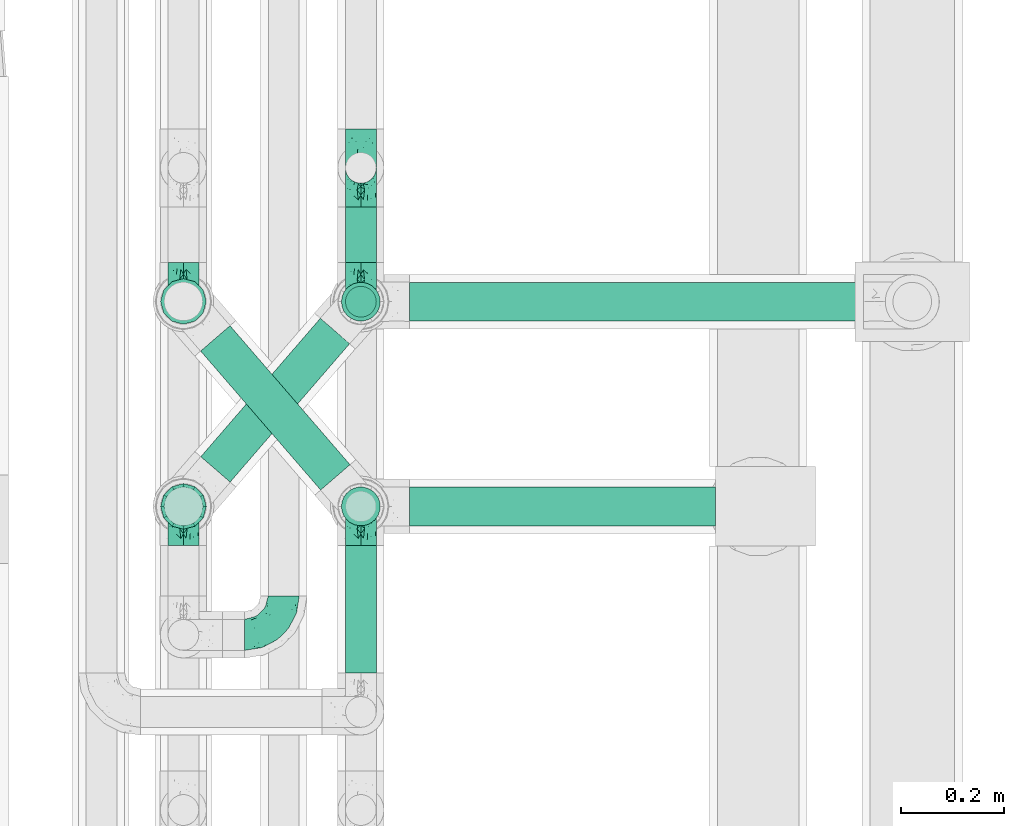
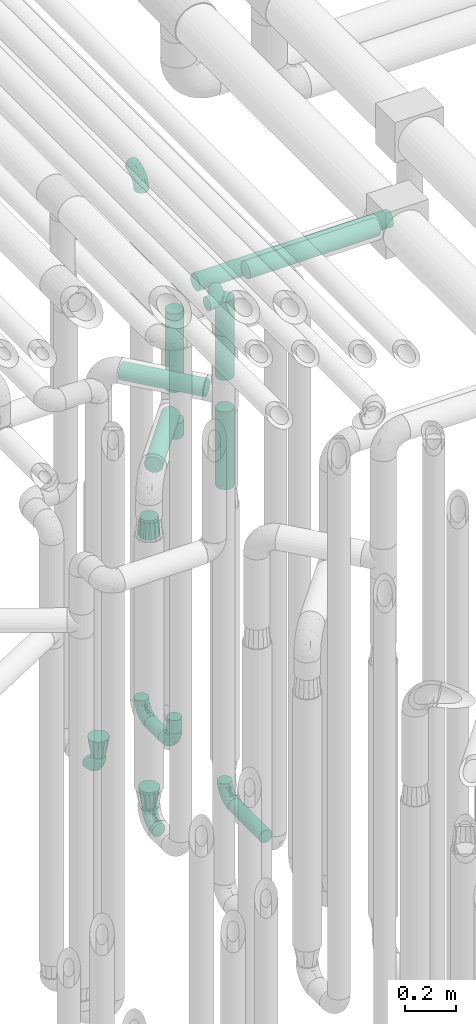
# One storey, part 625 of 827: 11 flow segments, 10 flow fittings.
"""IFC2X3 building model written with IfcOpenShell, lengths in millimetres."""

from ifc_helpers import new_model, entity, si_unit, converted_unit, derived_unit, direction, frame, origin, origin_2d_with_axis, place, context, subcontext, project, spatial, circle, extrude, faceted_brep, source, transform, mapped, material, type_object, type_shapes, element, save


model = new_model("IFC2X3")

# Units and contexts
model_context = context("Model", 3, precision=0.01, world=origin(), true_north=direction((6.12303176911189e-17, 1.0)))
body_context = subcontext(model_context, "Body", "Model", "MODEL_VIEW")
ifc_project = project(units=[si_unit("LENGTHUNIT", "METRE", prefix="MILLI"), si_unit("AREAUNIT", "SQUARE_METRE"), si_unit("VOLUMEUNIT", "CUBIC_METRE"), converted_unit("PLANEANGLEUNIT", "DEGREE", entity("IfcRatioMeasure", 0.0174532925199433), si_unit("PLANEANGLEUNIT", "RADIAN"), dimensions=[0, 0, 0, 0, 0, 0, 0]), si_unit("MASSUNIT", "GRAM", prefix="KILO"), derived_unit("MASSDENSITYUNIT", [(si_unit("MASSUNIT", "GRAM", prefix="KILO"), 1), (si_unit("LENGTHUNIT", "METRE"), -3)]), derived_unit("MOMENTOFINERTIAUNIT", [(si_unit("LENGTHUNIT", "METRE"), 4)]), si_unit("TIMEUNIT", "SECOND"), si_unit("FREQUENCYUNIT", "HERTZ"), si_unit("THERMODYNAMICTEMPERATUREUNIT", "DEGREE_CELSIUS"), derived_unit("THERMALTRANSMITTANCEUNIT", [(si_unit("MASSUNIT", "GRAM", prefix="KILO"), 1), (si_unit("THERMODYNAMICTEMPERATUREUNIT", "KELVIN"), -1), (si_unit("TIMEUNIT", "SECOND"), -3)]), derived_unit("VOLUMETRICFLOWRATEUNIT", [(si_unit("LENGTHUNIT", "METRE"), 3), (si_unit("TIMEUNIT", "SECOND"), -1)]), derived_unit("MASSFLOWRATEUNIT", [(si_unit("MASSUNIT", "GRAM", prefix="KILO"), 1), (si_unit("TIMEUNIT", "SECOND"), -1)]), derived_unit("ROTATIONALFREQUENCYUNIT", [(si_unit("TIMEUNIT", "SECOND"), -1)]), si_unit("ELECTRICCURRENTUNIT", "AMPERE"), si_unit("ELECTRICVOLTAGEUNIT", "VOLT"), si_unit("POWERUNIT", "WATT"), si_unit("FORCEUNIT", "NEWTON", prefix="KILO"), si_unit("ILLUMINANCEUNIT", "LUX"), si_unit("LUMINOUSFLUXUNIT", "LUMEN"), si_unit("LUMINOUSINTENSITYUNIT", "CANDELA"), derived_unit("USERDEFINED", [(si_unit("MASSUNIT", "GRAM", prefix="KILO"), -1), (si_unit("LENGTHUNIT", "METRE"), -2), (si_unit("TIMEUNIT", "SECOND"), 3), (si_unit("LUMINOUSFLUXUNIT", "LUMEN"), 1)]), derived_unit("LINEARVELOCITYUNIT", [(si_unit("LENGTHUNIT", "METRE"), 1), (si_unit("TIMEUNIT", "SECOND"), -1)]), si_unit("PRESSUREUNIT", "PASCAL"), derived_unit("USERDEFINED", [(si_unit("LENGTHUNIT", "METRE"), -2), (si_unit("MASSUNIT", "GRAM", prefix="KILO"), 1), (si_unit("TIMEUNIT", "SECOND"), -2)]), derived_unit("LINEARFORCEUNIT", [(si_unit("MASSUNIT", "GRAM", prefix="KILO"), 1), (si_unit("LENGTHUNIT", "METRE"), 1), (si_unit("TIMEUNIT", "SECOND"), -2), (si_unit("LENGTHUNIT", "METRE"), -1)]), derived_unit("PLANARFORCEUNIT", [(si_unit("MASSUNIT", "GRAM", prefix="KILO"), 1), (si_unit("LENGTHUNIT", "METRE"), 1), (si_unit("TIMEUNIT", "SECOND"), -2), (si_unit("LENGTHUNIT", "METRE"), -2)])], contexts=[model_context])

# Site, building, storey
site_placement = place(None, origin())
site = spatial("IfcSite", under=ifc_project, at=site_placement, CompositionType="ELEMENT")
building_placement = place(site_placement, origin())
building = spatial("IfcBuilding", under=site, at=building_placement, CompositionType="ELEMENT")
storey_placement = place(building_placement, frame((0.0, 0.0, 28200.0)))
storey = spatial("IfcBuildingStorey", under=building, at=storey_placement, Name="08", CompositionType="ELEMENT", Elevation=28200.0)

# Flow segments
pipe_segment_type = type_object("IfcPipeSegmentType", PredefinedType="NOTDEFINED")
flow_segment_1_placement = place(storey_placement, frame((36943.44, 12257.17, 368.4)))
element("IfcFlowSegment", 1, at=flow_segment_1_placement, inside=storey, type_object=pipe_segment_type, context=body_context, shape_type="SweptSolid", body=[
    extrude(circle(Radius=30.0, at=origin_2d_with_axis()), frame((31.6, 0.0, 31.6), z_axis=(0.0, 1.0, 0.0), x_axis=(1.0, 0.0, 0.0)), (0.0, 0.0, 1.0), 247.999981999989),
])
flow_segment_2_placement = place(storey_placement, frame((36943.44, 13055.64, 368.4)))
element("IfcFlowSegment", 2, at=flow_segment_2_placement, inside=storey, type_object=pipe_segment_type, context=body_context, shape_type="SweptSolid", body=[
    extrude(circle(Radius=30.0, at=origin_2d_with_axis()), frame((31.6, 0.0, 31.6), z_axis=(0.0, 1.0, 0.0), x_axis=(-1.0, 0.0, 0.0)), (0.0, 0.0, 1.0), 108.562571608464),
])
flow_segment_3_placement = place(storey_placement, frame((36943.44, 12948.05, 476.0)))
element("IfcFlowSegment", 3, at=flow_segment_3_placement, inside=storey, type_object=pipe_segment_type, context=body_context, shape_type="SweptSolid", body=[
    extrude(circle(Radius=30.0, at=origin_2d_with_axis()), frame((31.6, 31.6, 0.0)), (0.0, 0.0, 1.0), 64.0000000000244),
])
flow_segment_4_placement = place(storey_placement, frame((36935.69, 12940.3, 2126.0)))
element("IfcFlowSegment", 4, at=flow_segment_4_placement, inside=storey, type_object=pipe_segment_type, context=body_context, shape_type="SweptSolid", body=[
    extrude(circle(Radius=37.75, at=origin_2d_with_axis()), frame((39.35, 39.35, 0.0), z_axis=(0.0, 0.0, 1.0), x_axis=(-1.0, 0.0, 0.0)), (0.0, 0.0, 1.0), 378.999999999992),
])
flow_segment_5_placement = place(storey_placement, frame((37070.03, 12940.3, 2560.65)))
element("IfcFlowSegment", 5, at=flow_segment_5_placement, inside=storey, type_object=pipe_segment_type, context=body_context, shape_type="SweptSolid", body=[
    extrude(circle(Radius=37.75, at=origin_2d_with_axis()), frame((0.0, 39.35, 39.35), z_axis=(1.0, 0.0, 0.0), x_axis=(0.0, -1.0, 0.0)), (0.0, 0.0, 1.0), 883.265688415884),
])
flow_segment_6_placement = place(storey_placement, frame((36935.69, 12541.83, 2426.0)))
element("IfcFlowSegment", 6, at=flow_segment_6_placement, inside=storey, type_object=pipe_segment_type, context=body_context, shape_type="SweptSolid", body=[
    extrude(circle(Radius=37.75, at=origin_2d_with_axis()), frame((39.35, 39.35, 0.0), z_axis=(-2.14503310068031e-08, 1.89574983412965e-07, 1.0), x_axis=(-1.0, 0.0, -2.14503310068034e-08)), (0.0, 0.0, 1.0), 378.904960794338),
])
flow_segment_7_placement = place(storey_placement, frame((37070.03, 12541.83, 2860.56)))
element("IfcFlowSegment", 7, at=flow_segment_7_placement, inside=storey, type_object=pipe_segment_type, context=body_context, shape_type="SweptSolid", body=[
    extrude(circle(Radius=37.75, at=origin_2d_with_axis()), frame((0.0, 39.35, 39.35), z_axis=(1.0, 0.0, 0.0), x_axis=(0.0, 1.0, 0.0)), (0.0, 0.0, 1.0), 595.765098762424),
])
flow_segment_8_placement = place(storey_placement, frame((36661.57, 12611.47, 2310.65)))
element("IfcFlowSegment", 8, at=flow_segment_8_placement, inside=storey, type_object=pipe_segment_type, context=body_context, shape_type="SweptSolid", body=[
    extrude(circle(Radius=37.75, at=origin_2d_with_axis()), frame((30.17, 296.83, 39.35), z_axis=(0.65359148401651, -0.756847522306242, 0.0), x_axis=(-0.756847522306242, -0.65359148401651, 0.0)), (0.0, 0.0, 1.0), 357.482862990724),
])
flow_segment_9_placement = place(storey_placement, frame((36935.69, 12541.83, 1900.0)))
element("IfcFlowSegment", 9, at=flow_segment_9_placement, inside=storey, type_object=pipe_segment_type, context=body_context, shape_type="SweptSolid", body=[
    extrude(circle(Radius=37.75, at=origin_2d_with_axis()), frame((39.35, 39.35, 0.0), z_axis=(0.0, 0.0, 1.0), x_axis=(-1.0, 0.0, 0.0)), (0.0, 0.0, 1.0), 374.000000000002),
])
flow_segment_10_placement = place(storey_placement, frame((36661.85, 12626.98, 2010.65)))
element("IfcFlowSegment", 10, at=flow_segment_10_placement, inside=storey, type_object=pipe_segment_type, context=body_context, shape_type="SweptSolid", body=[
    extrude(circle(Radius=37.75, at=origin_2d_with_axis()), frame((30.17, 26.27, 39.35), z_axis=(0.653617255256322, 0.756825266247891, 0.0), x_axis=(0.756825266247891, -0.653617255256322, 0.0)), (0.0, 0.0, 1.0), 356.010747294406),
])
flow_segment_11_placement = place(storey_placement, frame((36935.69, 12940.3, 1900.0)))
element("IfcFlowSegment", 11, at=flow_segment_11_placement, inside=storey, type_object=pipe_segment_type, context=body_context, shape_type="SweptSolid", body=[
    extrude(circle(Radius=37.75, at=origin_2d_with_axis()), frame((39.35, 39.35, 0.0), z_axis=(0.0, 0.0, 1.0), x_axis=(-1.0, 0.0, 0.0)), (0.0, 0.0, 1.0), 74.0000000000005),
])

# Flow fittings
ifc_material = material()
pipe_fitting_type_1 = type_object("IfcPipeFittingType", Name="ADSK_1", PredefinedType="NOTDEFINED", material=ifc_material)
shared_shape_1 = source(origin(), body_context, "Body", "Brep", [
    faceted_brep([(-76.0, 15.07, -26.11), (-76.0, 7.8, -29.12), (-76.0, 0.0, -30.15), (-76.0, -7.8, -29.12), (-76.0, -15.08, -26.11), (-76.0, -21.32, -21.32), (-76.0, -26.11, -15.08), (-76.0, -29.12, -7.8), (-76.0, -30.15, 0.0), (-76.0, -29.12, 7.8), (-76.0, -26.11, 15.07), (-76.0, -21.32, 21.32), (-76.0, -15.08, 26.11), (-76.0, -7.8, 29.12), (-76.0, 0.0, 30.15), (-76.0, 7.8, 29.12), (-76.0, 15.07, 26.11), (-76.0, 21.32, 21.32), (-76.0, 26.11, 15.07), (-76.0, 29.12, 7.8), (-76.0, 30.15, 0.0), (-76.0, 29.12, -7.8), (-76.0, 26.11, -15.08), (-76.0, 21.32, -21.32), (0.0, 76.0, -30.15), (-7.8, 76.0, -29.12), (-15.07, 76.0, -26.11), (-21.32, 76.0, -21.32), (-26.11, 76.0, -15.08), (-29.12, 76.0, -7.8), (-30.15, 76.0, 0.0), (-29.12, 76.0, 7.8), (-26.11, 76.0, 15.07), (-21.32, 76.0, 21.32), (-15.07, 76.0, 26.11), (-7.8, 76.0, 29.12), (0.0, 76.0, 30.15), (7.8, 76.0, 29.12), (15.08, 76.0, 26.11), (21.32, 76.0, 21.32), (26.11, 76.0, 15.07), (29.12, 76.0, 7.8), (30.15, 76.0, 0.0), (29.12, 76.0, -7.8), (26.11, 76.0, -15.08), (21.32, 76.0, -21.32), (15.08, 76.0, -26.11), (7.8, 76.0, -29.12), (10.79, 31.43, 21.07), (4.32, 31.7, 25.72), (1.65, 15.19, 19.92), (-61.17, -27.8, 0.0), (-51.1, -25.49, 9.84), (-56.14, -10.61, 27.27), (-31.7, -4.32, 25.72), (-39.75, 1.72, 29.41), (-43.2, -24.95, 0.0), (-1.86, 1.86, 0.0), (4.49, 7.65, 5.78), (-7.82, -4.61, 5.83), (-56.21, -22.79, 17.21), (-58.98, -3.38, 29.7), (-53.96, 5.6, 30.07), (-10.86, 10.86, 25.48), (-17.2, -2.6, 20.44), (-49.15, -16.01, 22.7), (-22.18, -14.24, 7.99), (-28.4, -17.42, 0.0), (-13.61, -9.88, 0.0), (-39.0, 23.48, 27.76), (-58.76, 12.54, 28.36), (-41.61, 15.41, 29.48), (16.01, 49.15, 22.7), (-58.55, 25.93, 19.53), (-51.53, 33.5, 13.51), (-64.92, 28.76, 12.4), (-7.48, 23.14, 28.25), (-1.72, 39.75, 29.41), (-12.04, 27.88, 29.88), (-63.91, 18.81, 24.52), (-11.63, 65.16, 28.18), (-4.97, 57.02, 30.05), (9.88, 13.61, 0.0), (-62.5, 31.74, 5.02), (-45.17, 30.98, 21.2), (-21.78, 9.76, 28.58), (10.61, 56.14, 27.27), (-32.09, 54.42, 13.26), (22.79, 56.21, 17.21), (15.38, 31.17, 15.63), (25.49, 51.1, 9.84), (21.84, 36.35, 5.92), (24.95, 43.2, 0.0), (3.38, 58.98, 29.7), (-31.17, -15.38, 15.63), (-39.39, 41.78, 15.45), (-34.56, 41.13, 20.79), (-39.81, -23.25, 5.49), (27.8, 61.17, 0.0), (-31.74, 62.5, 5.02), (-53.07, 36.29, 0.0), (-42.95, 42.95, 7.29), (-36.29, 53.07, 0.0), (-19.83, 58.51, 24.79), (-25.48, 60.2, 19.41), (-14.53, 50.96, 28.57), (-13.31, 37.09, 30.07), (-26.16, 40.06, 26.4), (-32.43, -10.35, 21.9), (17.42, 28.4, 0.0), (14.24, 22.18, 7.99), (-38.67, 9.72, 30.15), (-24.66, 17.36, 30.09), (-37.08, 31.49, 24.99), (-49.27, 22.83, 25.24), (-20.8, 38.81, 28.63), (-27.58, 27.58, 29.2), (-36.07, -20.23, 10.71), (-15.19, -6.16, 14.9), (6.6, 15.4, 14.49), (-2.51, 2.51, 11.35), (-65.16, 11.63, -28.18), (-49.15, -16.01, -22.7), (-57.02, 4.97, -30.05), (-25.93, 58.55, -19.53), (-33.5, 51.53, -13.51), (-28.76, 64.92, -12.4), (-60.2, 25.48, -19.41), (-58.51, 19.83, -24.79), (4.61, 7.82, -5.83), (-7.65, -4.49, -5.78), (-2.51, 2.51, -11.35), (-62.5, 31.74, -5.02), (-50.96, 14.53, -28.57), (-37.09, 13.31, -30.07), (-42.95, 42.95, -7.29), (25.49, 51.1, -9.84), (22.79, 56.21, -17.21), (-40.06, 26.16, -26.4), (3.38, 58.98, -29.7), (-5.6, 53.96, -30.07), (-27.88, 12.04, -29.88), (-9.76, 21.78, -28.58), (-23.14, 7.48, -28.25), (-51.1, -25.49, -9.84), (15.38, 31.17, -15.63), (16.01, 49.15, -22.7), (-23.48, 39.0, -27.76), (-12.54, 58.76, -28.36), (-15.41, 41.61, -29.48), (-56.21, -22.79, -17.21), (-9.72, 38.67, -30.15), (-17.36, 24.66, -30.09), (-22.18, -14.24, -7.99), (-41.13, 34.56, -20.79), (-31.74, 62.5, -5.02), (-58.98, -3.38, -29.7), (-31.17, -15.38, -15.63), (-56.14, -10.61, -27.27), (14.24, 22.18, -7.99), (23.25, 39.81, -5.49), (-31.49, 37.08, -24.99), (-15.19, -6.16, -14.9), (1.65, 15.19, -19.92), (-18.81, 63.91, -24.52), (-32.59, -11.62, -20.84), (-31.7, -4.32, -25.72), (-17.2, -2.6, -20.44), (-39.75, 1.72, -29.41), (-54.42, 32.09, -13.26), (-30.98, 45.17, -21.2), (10.61, 56.14, -27.27), (10.23, 31.31, -21.52), (4.32, 31.7, -25.72), (-41.78, 39.39, -15.45), (-1.72, 39.75, -29.41), (-36.35, -21.84, -5.92), (-22.83, 49.27, -25.24), (-38.81, 20.8, -28.63), (-27.58, 27.58, -29.2), (-10.86, 10.86, -25.48), (20.23, 36.07, -10.71), (6.6, 15.4, -14.49)], [[[0, 1, 2, 3, 4, 5, 6, 7, 8, 9, 10, 11, 12, 13, 14, 15, 16, 17, 18, 19, 20, 21, 22, 23]], [[24, 25, 26, 27, 28, 29, 30, 31, 32, 33, 34, 35, 36, 37, 38, 39, 40, 41, 42, 43, 44, 45, 46, 47]], [[48, 49, 50]], [[51, 52, 9]], [[53, 54, 55]], [[9, 52, 10]], [[56, 52, 51]], [[57, 58, 59]], [[11, 10, 60]], [[14, 61, 62]], [[63, 54, 64]], [[65, 12, 11]], [[65, 53, 12]], [[66, 67, 68]], [[69, 70, 71]], [[72, 39, 38]], [[73, 74, 75]], [[15, 70, 16]], [[76, 77, 78]], [[16, 79, 17]], [[13, 61, 14]], [[35, 80, 81]], [[14, 62, 15]], [[17, 73, 18]], [[57, 82, 58]], [[20, 19, 83]], [[75, 19, 18]], [[70, 15, 62]], [[73, 84, 74]], [[78, 85, 76]], [[38, 86, 72]], [[32, 31, 87]], [[88, 89, 90]], [[91, 92, 90]], [[72, 86, 49]], [[36, 93, 37]], [[75, 83, 19]], [[36, 35, 81]], [[60, 94, 65]], [[40, 90, 41]], [[95, 96, 87]], [[88, 90, 40]], [[66, 97, 67]], [[90, 98, 41]], [[40, 39, 88]], [[99, 31, 30]], [[20, 83, 100]], [[101, 102, 100]], [[52, 60, 10]], [[102, 99, 30]], [[96, 103, 104]], [[83, 101, 100]], [[12, 53, 13]], [[104, 103, 33]], [[105, 106, 81]], [[107, 105, 103]], [[64, 54, 108]], [[80, 103, 105]], [[80, 35, 34]], [[34, 33, 103]], [[86, 38, 37]], [[109, 110, 82]], [[71, 111, 112]], [[69, 107, 113]], [[79, 73, 17]], [[114, 113, 84]], [[33, 32, 104]], [[115, 107, 116]], [[105, 115, 106]], [[93, 81, 77]], [[54, 53, 65]], [[61, 53, 55]], [[108, 94, 64]], [[54, 63, 85]], [[93, 86, 37]], [[77, 76, 49]], [[77, 49, 86]], [[49, 63, 50]], [[60, 52, 117]], [[65, 11, 60]], [[39, 72, 88]], [[89, 88, 72]], [[71, 70, 62]], [[79, 70, 114]], [[103, 96, 107]], [[69, 113, 114]], [[112, 106, 116]], [[77, 81, 106]], [[112, 116, 71]], [[112, 55, 85]], [[64, 50, 63]], [[57, 59, 68]], [[32, 87, 104]], [[96, 104, 87]], [[94, 118, 64]], [[50, 119, 89]], [[50, 64, 118]], [[50, 89, 48]], [[81, 93, 36]], [[86, 93, 77]], [[53, 61, 13]], [[62, 61, 55]], [[71, 62, 111]], [[69, 71, 116]], [[95, 101, 74]], [[99, 101, 87]], [[118, 66, 59]], [[117, 97, 66]], [[117, 66, 94]], [[91, 89, 110]], [[91, 110, 109]], [[110, 89, 119]], [[9, 8, 51]], [[98, 90, 92]], [[98, 42, 41]], [[101, 83, 74]], [[101, 99, 102]], [[87, 31, 99]], [[62, 55, 111]], [[55, 112, 111]], [[107, 69, 116]], [[70, 69, 114]], [[107, 96, 113]], [[84, 113, 96]], [[84, 96, 95]], [[114, 84, 73]], [[70, 79, 16]], [[73, 79, 114]], [[54, 85, 55]], [[76, 85, 63]], [[49, 76, 63]], [[77, 106, 78]], [[106, 112, 78]], [[85, 78, 112]], [[73, 75, 18]], [[83, 75, 74]], [[103, 80, 34]], [[81, 80, 105]], [[101, 95, 87]], [[84, 95, 74]], [[106, 115, 116]], [[105, 107, 115]], [[120, 59, 58]], [[82, 110, 58]], [[119, 58, 110]], [[118, 59, 120]], [[66, 68, 59]], [[54, 65, 108]], [[94, 108, 65]], [[66, 118, 94]], [[50, 118, 120]], [[50, 120, 119]], [[119, 120, 58]], [[89, 72, 48]], [[49, 48, 72]], [[60, 117, 94]], [[117, 52, 97]], [[52, 56, 97]], [[67, 97, 56]], [[92, 91, 109]], [[89, 91, 90]], [[121, 1, 0]], [[122, 5, 4]], [[2, 1, 123]], [[124, 125, 126]], [[127, 128, 23]], [[129, 130, 131]], [[100, 132, 20]], [[133, 134, 123]], [[135, 100, 102]], [[136, 137, 44]], [[133, 128, 138]], [[24, 139, 140]], [[141, 142, 143]], [[121, 128, 133]], [[6, 144, 7]], [[137, 145, 146]], [[144, 51, 7]], [[147, 148, 149]], [[144, 6, 150]], [[149, 151, 152]], [[153, 68, 67]], [[154, 128, 127]], [[30, 155, 102]], [[43, 42, 98]], [[156, 3, 2]], [[157, 144, 150]], [[158, 4, 3]], [[24, 140, 25]], [[155, 135, 102]], [[159, 160, 109]], [[30, 29, 155]], [[147, 138, 161]], [[27, 124, 28]], [[57, 129, 82]], [[162, 163, 131]], [[27, 26, 164]], [[148, 26, 25]], [[165, 166, 167]], [[24, 47, 139]], [[143, 168, 141]], [[22, 21, 169]], [[125, 124, 170]], [[148, 25, 140]], [[46, 146, 171]], [[158, 122, 4]], [[0, 23, 128]], [[1, 121, 123]], [[109, 82, 159]], [[45, 44, 137]], [[146, 46, 45]], [[136, 43, 98]], [[132, 21, 20]], [[136, 98, 92]], [[172, 173, 146]], [[46, 171, 47]], [[43, 136, 44]], [[174, 154, 169]], [[171, 173, 175]], [[6, 5, 150]], [[126, 29, 28]], [[176, 56, 144]], [[122, 158, 166]], [[164, 124, 27]], [[177, 161, 170]], [[23, 22, 127]], [[178, 138, 179]], [[133, 178, 134]], [[156, 123, 168]], [[156, 158, 3]], [[168, 143, 166]], [[168, 166, 158]], [[166, 180, 167]], [[173, 171, 146]], [[139, 171, 175]], [[172, 145, 163]], [[173, 180, 142]], [[5, 122, 150]], [[157, 150, 122]], [[137, 136, 181]], [[146, 45, 137]], [[149, 148, 140]], [[164, 148, 177]], [[128, 154, 138]], [[147, 161, 177]], [[152, 134, 179]], [[168, 123, 134]], [[152, 179, 149]], [[152, 175, 142]], [[57, 130, 129]], [[157, 165, 167]], [[22, 169, 127]], [[154, 127, 169]], [[163, 167, 180]], [[162, 157, 167]], [[173, 163, 180]], [[182, 163, 145]], [[123, 156, 2]], [[158, 156, 168]], [[171, 139, 47]], [[140, 139, 175]], [[149, 140, 151]], [[147, 149, 179]], [[174, 135, 125]], [[132, 135, 169]], [[176, 157, 153]], [[176, 153, 67]], [[153, 157, 162]], [[182, 159, 129]], [[181, 160, 159]], [[181, 159, 145]], [[51, 144, 56]], [[51, 8, 7]], [[135, 132, 100]], [[169, 21, 132]], [[126, 155, 29]], [[135, 155, 125]], [[140, 175, 151]], [[175, 152, 151]], [[138, 147, 179]], [[148, 147, 177]], [[138, 154, 161]], [[170, 161, 154]], [[170, 154, 174]], [[177, 170, 124]], [[148, 164, 26]], [[124, 164, 177]], [[173, 142, 175]], [[143, 142, 180]], [[166, 143, 180]], [[168, 134, 141]], [[134, 152, 141]], [[142, 141, 152]], [[124, 126, 28]], [[155, 126, 125]], [[128, 121, 0]], [[123, 121, 133]], [[135, 174, 169]], [[170, 174, 125]], [[134, 178, 179]], [[133, 138, 178]], [[130, 153, 162]], [[68, 153, 130]], [[57, 68, 130]], [[182, 129, 131]], [[159, 82, 129]], [[157, 122, 165]], [[166, 165, 122]], [[163, 162, 167]], [[162, 131, 130]], [[145, 172, 146]], [[163, 173, 172]], [[159, 182, 145]], [[131, 163, 182]], [[56, 176, 67]], [[157, 176, 144]], [[137, 181, 145]], [[181, 136, 160]], [[136, 92, 160]], [[109, 160, 92]]]),
])
type_shapes(pipe_fitting_type_1, [shared_shape_1])
for number, where, z_axis, x_axis, name in (
    (12, (36975.03, 12581.17, 400.0), (1.0, 0.0, 0.0), (0.0, 1.0, 0.0), "ADSK_1"),
    (13, (36975.03, 13240.2, 400.0), (-1.0, 0.0, 0.0), (0.0, 0.0, -1.0), "ADSK_1"),
    (14, (36975.03, 12979.64, 400.0), (-1.0, 0.0, 0.0), (0.0, -1.0, 0.0), "ADSK_1"),
    (15, (36975.03, 13240.2, 3000.0), (-1.0, 0.0, 0.0), (0.0, 0.0, 1.0), "ADSK_1"),
):
    element("IfcFlowFitting", number, at=place(storey_placement, frame(where, z_axis=z_axis, x_axis=x_axis)), inside=storey, type_object=pipe_fitting_type_1, material=ifc_material, Name=name, ObjectType="ADSK_1", context=body_context, shape_type="MappedRepresentation", body=[
        mapped(shared_shape_1, transform((0.0, 0.0, 0.0), scale=1.0)),
    ])
flow_fitting_1_placement = place(storey_placement, frame((36825.03, 12331.17, 3000.0)))
element("IfcFlowFitting", 16, at=flow_fitting_1_placement, inside=storey, type_object=pipe_fitting_type_1, material=ifc_material, Name="ADSK_1", ObjectType="ADSK_1", context=body_context, shape_type="MappedRepresentation", body=[
    mapped(shared_shape_1, transform((0.0, 0.0, 0.0), scale=1.0)),
])
for number, where, z_axis, x_axis, name in (
    (17, (36629.64, 12980.2, 400.0), (-1.0, 0.0, 0.0), (0.0, -1.0, 0.0), "ADSK_1"),
    (18, (36629.64, 12581.17, 400.0), (0.999999979696238, 0.0, -0.000201513087664095), (0.0, 1.0, 0.0), "ADSK_1"),
):
    element("IfcFlowFitting", number, at=place(storey_placement, frame(where, z_axis=z_axis, x_axis=x_axis)), inside=storey, type_object=pipe_fitting_type_1, material=ifc_material, Name=name, ObjectType="ADSK_1", context=body_context, shape_type="MappedRepresentation", body=[
        mapped(shared_shape_1, transform((0.0, 0.0, 0.0), scale=1.0)),
    ])
pipe_fitting_type_2 = type_object("IfcPipeFittingType", Name="ADSK_1", PredefinedType="NOTDEFINED", material=ifc_material)
shared_shape_2 = source(origin(), body_context, "Body", "Brep", [
    faceted_brep([(89.0, -44.45, 0.0), (89.0, -42.1, -8.76), (89.0, -38.49, -22.22), (89.0, -30.36, -30.36), (89.0, -22.23, -38.49), (89.0, -11.11, -41.47), (89.0, 0.0, -44.45), (89.0, 11.11, -41.47), (89.0, 22.22, -38.49), (89.0, 30.36, -30.36), (89.0, 38.49, -22.22), (89.0, 42.1, -8.76), (89.0, 44.45, 0.0), (89.0, 42.1, 8.76), (89.0, 38.49, 22.23), (89.0, 30.36, 30.36), (89.0, 22.22, 38.49), (89.0, 11.11, 41.47), (89.0, 0.0, 44.45), (89.0, -11.11, 41.47), (89.0, -22.23, 38.49), (89.0, -30.36, 30.36), (89.0, -38.49, 22.23), (89.0, -42.1, 8.76), (0.0, 30.15, 0.0), (0.0, 27.27, -8.86), (0.0, 24.39, -17.72), (0.0, 16.85, -23.2), (0.0, 9.32, -28.67), (0.0, 0.0, -28.67), (0.0, -9.32, -28.67), (0.0, -16.85, -23.2), (0.0, -24.39, -17.72), (0.0, -27.27, -8.86), (0.0, -30.15, 0.0), (0.0, -27.27, 8.86), (0.0, -24.39, 17.72), (0.0, -16.85, 23.2), (0.0, -9.32, 28.67), (0.0, 0.0, 28.67), (0.0, 9.32, 28.67), (0.0, 16.85, 23.2), (0.0, 24.39, 17.72), (0.0, 27.27, 8.86)], [[[0, 1, 2, 3, 4, 5, 6, 7, 8, 9, 10, 11, 12, 13, 14, 15, 16, 17, 18, 19, 20, 21, 22, 23]], [[24, 25, 26, 27, 28, 29, 30, 31, 32, 33, 34, 35, 36, 37, 38, 39, 40, 41, 42, 43]], [[2, 33, 32]], [[28, 7, 29]], [[29, 5, 30]], [[24, 12, 11]], [[3, 32, 31]], [[34, 1, 0]], [[1, 34, 33]], [[8, 28, 27]], [[2, 1, 33]], [[31, 4, 3]], [[2, 32, 3]], [[11, 25, 24]], [[26, 10, 9]], [[10, 25, 11]], [[28, 8, 7]], [[27, 26, 9]], [[26, 25, 10]], [[31, 30, 4]], [[8, 27, 9]], [[29, 7, 6]], [[5, 29, 6]], [[5, 4, 30]], [[14, 43, 42]], [[38, 19, 39]], [[39, 17, 40]], [[34, 0, 23]], [[15, 42, 41]], [[24, 13, 12]], [[13, 24, 43]], [[20, 38, 37]], [[14, 13, 43]], [[41, 16, 15]], [[14, 42, 15]], [[23, 35, 34]], [[36, 22, 21]], [[22, 35, 23]], [[38, 20, 19]], [[37, 36, 21]], [[36, 35, 22]], [[41, 40, 16]], [[20, 37, 21]], [[39, 19, 18]], [[17, 39, 18]], [[17, 16, 40]]]),
])
type_shapes(pipe_fitting_type_2, [shared_shape_2])
for number, where, z_axis, x_axis, name in (
    (19, (36629.64, 12980.2, 476.0), (1.0, 0.0, 0.0), (0.0, 0.0, 1.0), "ADSK_1"),
    (20, (36629.66, 12581.17, 476.0), (0.0, 1.0, 0.0), (0.000201513087664095, 0.0, 0.999999979696238), "ADSK_1"),
):
    element("IfcFlowFitting", number, at=place(storey_placement, frame(where, z_axis=z_axis, x_axis=x_axis)), inside=storey, type_object=pipe_fitting_type_2, material=ifc_material, Name=name, ObjectType="ADSK_1", context=body_context, shape_type="MappedRepresentation", body=[
        mapped(shared_shape_2, transform((0.0, 0.0, 0.0), scale=1.0)),
    ])
pipe_fitting_type_3 = type_object("IfcPipeFittingType", Name="ADSK_1", PredefinedType="NOTDEFINED", material=ifc_material)
shared_shape_3 = source(origin(), body_context, "Body", "Brep", [
    faceted_brep([(89.0, 38.05, 0.0), (89.0, 35.5, 9.51), (89.0, 32.95, 19.03), (89.0, 25.99, 25.99), (89.0, 19.02, 32.95), (89.0, 9.51, 35.5), (89.0, 0.0, 38.05), (89.0, -9.51, 35.5), (89.0, -19.03, 32.95), (89.0, -25.99, 25.99), (89.0, -32.95, 19.03), (89.0, -35.5, 9.51), (89.0, -38.05, 0.0), (89.0, -35.5, -9.51), (89.0, -32.95, -19.02), (89.0, -25.99, -25.99), (89.0, -19.03, -32.95), (89.0, -9.51, -35.5), (89.0, 0.0, -38.05), (89.0, 9.51, -35.5), (89.0, 19.02, -32.95), (89.0, 25.99, -25.99), (89.0, 32.95, -19.03), (89.0, 35.5, -9.51), (0.0, -38.49, 22.22), (0.0, -30.36, 30.36), (0.0, -22.22, 38.49), (0.0, -11.11, 41.47), (0.0, 0.0, 44.45), (0.0, 11.11, 41.47), (0.0, 22.23, 38.49), (0.0, 30.36, 30.36), (0.0, 38.49, 22.22), (0.0, 41.96, 9.31), (0.0, 44.45, 0.0), (0.0, 41.47, -11.11), (0.0, 38.49, -22.23), (0.0, 30.36, -30.36), (0.0, 22.23, -38.49), (0.0, 11.11, -41.47), (0.0, 0.0, -44.45), (0.0, -11.11, -41.47), (0.0, -22.23, -38.49), (0.0, -30.36, -30.36), (0.0, -38.49, -22.23), (0.0, -41.96, -9.31), (0.0, -44.45, 0.0), (0.0, -41.47, 11.11)], [[[0, 1, 2, 3, 4, 5, 6, 7, 8, 9, 10, 11, 12, 13, 14, 15, 16, 17, 18, 19, 20, 21, 22, 23]], [[24, 25, 26, 27, 28, 29, 30, 31, 32, 33, 34, 35, 36, 37, 38, 39, 40, 41, 42, 43, 44, 45, 46, 47]], [[23, 22, 36, 35, 34, 0]], [[39, 38, 20, 19, 18, 40]], [[38, 37, 36, 22, 21, 20]], [[43, 42, 16, 15, 14, 44]], [[41, 40, 18, 17, 16, 42]], [[12, 46, 45, 44, 14, 13]], [[11, 10, 24, 47, 46, 12]], [[27, 26, 8, 7, 6, 28]], [[26, 25, 24, 10, 9, 8]], [[31, 30, 4, 3, 2, 32]], [[29, 28, 6, 5, 4, 30]], [[0, 34, 33, 32, 2, 1]]]),
])
type_shapes(pipe_fitting_type_3, [shared_shape_3])
flow_fitting_2_placement = place(storey_placement, frame((36629.92, 12581.17, 1781.0), z_axis=(0.0, 1.0, 0.0), x_axis=(0.000201513087669316, 0.0, 0.999999979696238)))
element("IfcFlowFitting", 21, at=flow_fitting_2_placement, inside=storey, type_object=pipe_fitting_type_3, material=ifc_material, Name="ADSK_1", ObjectType="ADSK_1", context=body_context, shape_type="MappedRepresentation", body=[
    mapped(shared_shape_3, transform((0.0, 0.0, 0.0), scale=1.0)),
])

save(model, "model.ifc")
